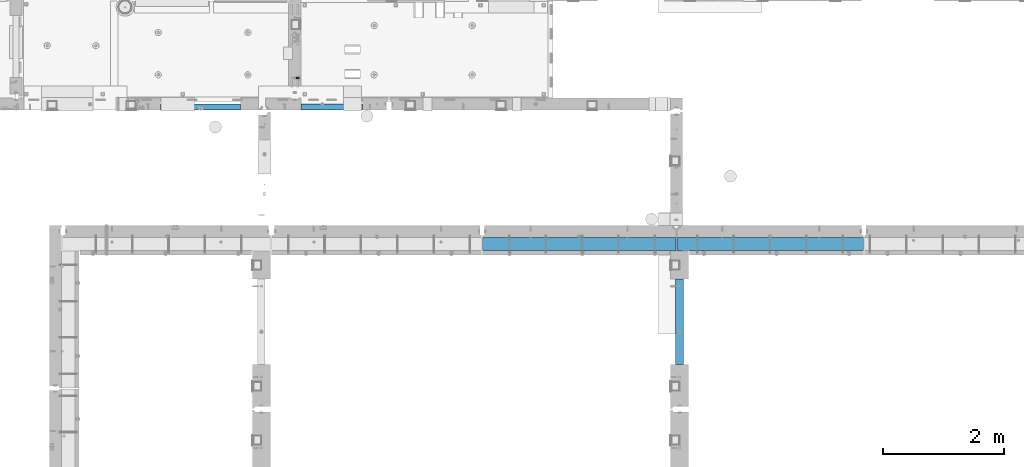
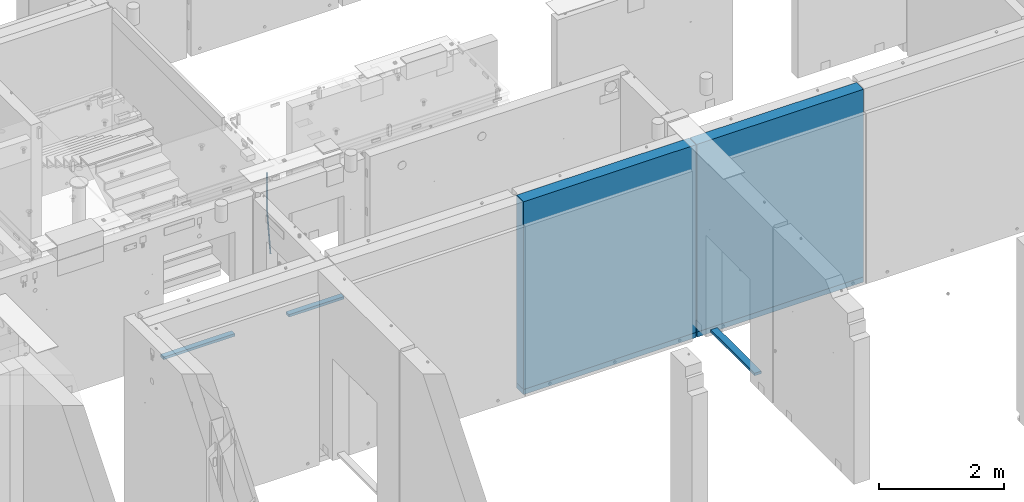
# One storey, part 80 of 264: 8 beams, 8 elements without a shape of their own.
"""IFC2X3 building model written with IfcOpenShell, lengths in millimetres."""

from ifc_helpers import new_model, si_unit, frame, origin_with_axes, place, context, subcontext, project, spatial, faceted_brep, material, type_object, element, aggregate, save


model = new_model("IFC2X3")

# Units and contexts
model_context = context("Model", 3, precision=1e-05, world=origin_with_axes())
body_context = subcontext(model_context, "Body", "Model", "MODEL_VIEW")
ifc_project = project(units=[si_unit("LENGTHUNIT", "METRE", prefix="MILLI"), si_unit("AREAUNIT", "SQUARE_METRE"), si_unit("VOLUMEUNIT", "CUBIC_METRE"), si_unit("MASSUNIT", "GRAM", prefix="KILO"), si_unit("TIMEUNIT", "SECOND"), si_unit("PLANEANGLEUNIT", "RADIAN"), si_unit("SOLIDANGLEUNIT", "STERADIAN"), si_unit("THERMODYNAMICTEMPERATUREUNIT", "DEGREE_CELSIUS"), si_unit("LUMINOUSINTENSITYUNIT", "LUMEN")], contexts=[model_context])

# Site, building, storey
site_placement = place(None, origin_with_axes())
site = spatial("IfcSite", under=ifc_project, at=site_placement, CompositionType="ELEMENT")
building_placement = place(site_placement, origin_with_axes())
building = spatial("IfcBuilding", under=site, at=building_placement, CompositionType="ELEMENT")
storey_placement = place(building_placement, origin_with_axes())
storey = spatial("IfcBuildingStorey", under=building, at=storey_placement, Name="K", CompositionType="ELEMENT", Elevation=0.0)

# Assembly, beam
assembly_1_placement = place(storey_placement, origin_with_axes())
assembly_1 = element("IfcElementAssembly", 1, at=assembly_1_placement, inside=storey, AssemblyPlace="NOTDEFINED", PredefinedType="REINFORCEMENT_UNIT")
ifc_material_1 = material()
beam_type_1 = type_object("IfcBeamType", Name="D20", PredefinedType="NOTDEFINED")
beam_1_placement = place(assembly_1_placement, frame((22375.0, 15610.0024460395, 79795.0), z_axis=(0.99735846233968, 0.0, 0.0726367510247368), x_axis=(-0.0726367510247384, 0.0, 0.99735846233968)))
beam_1 = element("IfcBeam", 2, at=beam_1_placement, type_object=beam_type_1, material=ifc_material_1, Name="JM20", ObjectType="D20", context=body_context, shape_type="Brep", body=[
    faceted_brep([(0.0, -10.0, 0.0), (-4.19531716033816e-08, -7.07106781186667, -7.07106781187031), (893.04549610398, -7.07106781186485, -7.0710675745504), (893.045496091479, -10.0, 2.30564182857051e-07), (0.0, 0.0, -10.0), (893.045496104736, 0.0, -9.99999976268737), (4.196772351861e-08, 7.07106781186303, -7.07106781186667), (893.04549610398, 7.07106781186485, -7.0710675745504), (0.0, 10.0, 0.0), (893.045496102088, 10.0, 2.37316271523014e-07), (4.196772351861e-08, 7.07106781185939, 7.07106781185939), (893.045496100211, 7.07106781186485, 7.0710680491793), (0.0, 0.0, 10.0), (893.045496099425, 0.0, 10.0000002373126), (-4.19531716033816e-08, -7.07106781187031, 7.07106781185939), (893.045496100211, -7.07106781186485, 7.0710680491793), (897.190953021025, -7.07106781186485, -6.92031220680656), (896.677333640066, -10.0, 0.132077120331815), (897.403701138901, 0.0, -9.84150751029665), (897.190953021025, 7.07106781186485, -6.92031220680656), (896.677333629617, 10.0, 0.132077113215928), (896.163714238195, 7.07106781186485, 7.18446643323841), (895.950966120377, 0.0, 10.1056617367321), (896.163714238195, -7.07106781186485, 7.18446643323841), (1601.00854794709, -7.07106781186485, 44.3381122681312), (1600.49492855495, -10.0, 51.3905015880737), (1601.22129606521, 0.0, 41.4169169646775), (1601.00854794709, 7.07106781186485, 44.3381122681312), (1600.49492855495, 10.0, 51.3905015880737), (1599.98130916282, 7.07106781186485, 58.4428909080125), (1599.76856104469, 0.0, 61.3640862114698), (1599.98130916282, -7.07106781186485, 58.4428909080125)], [[[0, 1, 2, 3]], [[1, 4, 5, 2]], [[4, 6, 7, 5]], [[6, 8, 9, 7]], [[8, 10, 11, 9]], [[10, 12, 13, 11]], [[12, 14, 15, 13]], [[14, 0, 3, 15]], [[14, 12, 10, 8, 6, 4, 1, 0]], [[3, 2, 16, 17]], [[2, 5, 18, 16]], [[5, 7, 19, 18]], [[7, 9, 20, 19]], [[9, 11, 21, 20]], [[11, 13, 22, 21]], [[13, 15, 23, 22]], [[15, 3, 17, 23]], [[17, 16, 24, 25]], [[16, 18, 26, 24]], [[18, 19, 27, 26]], [[19, 20, 28, 27]], [[20, 21, 29, 28]], [[21, 22, 30, 29]], [[22, 23, 31, 30]], [[23, 17, 25, 31]], [[26, 27, 28, 29, 30, 31, 25, 24]]]),
])
aggregate(assembly_1, [beam_1])

assembly_2_placement = place(storey_placement, origin_with_axes())
assembly_2 = element("IfcElementAssembly", 3, at=assembly_2_placement, inside=storey, AssemblyPlace="NOTDEFINED", PredefinedType="REINFORCEMENT_UNIT")
ifc_material_2 = material(Name="TIMBER/PUU")
beam_type_2 = type_object("IfcBeamType", PredefinedType="NOTDEFINED")
beam_2_placement = place(assembly_2_placement, frame((28660.0, 12290.0, 78115.0), z_axis=(0.0, 0.0, 1.0), x_axis=(0.0, -1.0, 0.0)))
beam_2 = element("IfcBeam", 4, at=beam_2_placement, type_object=beam_type_2, material=ifc_material_2, context=body_context, shape_type="Brep", body=[
    faceted_brep([(0.0, 62.5, -25.0), (0.0, 62.5, 25.0), (1410.00023037194, 62.5, 25.0), (1410.00023037194, 62.5, -25.0), (0.0, -62.5, 25.0), (1410.00023037194, -62.5, 25.0), (0.0, -62.5, -25.0), (1410.00023037194, -62.5, -25.0)], [[[0, 1, 2, 3]], [[1, 4, 5, 2]], [[4, 6, 7, 5]], [[6, 0, 3, 7]], [[5, 7, 3, 2]], [[6, 4, 1, 0]]]),
])
aggregate(assembly_2, [beam_2])

assembly_3_placement = place(storey_placement, origin_with_axes())
assembly_3 = element("IfcElementAssembly", 5, at=assembly_3_placement, inside=storey, AssemblyPlace="NOTDEFINED", PredefinedType="REINFORCEMENT_UNIT")
ifc_material_3 = material(Name="TIMBER/T24")
beam_type_3 = type_object("IfcBeamType", PredefinedType="NOTDEFINED")
beam_3_placement = place(assembly_3_placement, frame((22409.9994690485, 15130.0, 78880.0), z_axis=(0.0, 0.0, 1.0), x_axis=(1.0, 0.0, 0.0)))
beam_3 = element("IfcBeam", 6, at=beam_3_placement, type_object=beam_type_3, material=ifc_material_3, context=body_context, shape_type="Brep", body=[
    faceted_brep([(0.0, 50.0, -25.0), (0.0, 50.0, 25.0), (1019.99696415685, 50.0, 25.0), (1019.99696415685, 50.0, -25.0), (0.0, -50.0, 25.0), (1019.99696415685, -50.0, 25.0), (0.0, -50.0, -25.0), (1019.99696415685, -50.0, -25.0)], [[[0, 1, 2, 3]], [[1, 4, 5, 2]], [[4, 6, 7, 5]], [[6, 0, 3, 7]], [[5, 7, 3, 2]], [[6, 4, 1, 0]]]),
])
aggregate(assembly_3, [beam_3])

assembly_4_placement = place(storey_placement, origin_with_axes())
assembly_4 = element("IfcElementAssembly", 7, at=assembly_4_placement, inside=storey, AssemblyPlace="NOTDEFINED", PredefinedType="REINFORCEMENT_UNIT")
beam_4_placement = place(assembly_4_placement, frame((20094.9972693255, 15130.0, 78860.0), z_axis=(0.0, 0.0, 1.0), x_axis=(1.0, 0.0, 0.0)))
beam_4 = element("IfcBeam", 8, at=beam_4_placement, type_object=beam_type_3, material=ifc_material_3, context=body_context, shape_type="Brep", body=[
    faceted_brep([(0.0, 50.0, -25.0), (0.0, 50.0, 25.0), (1320.00518798828, 50.0, 25.0), (1320.00518798828, 50.0, -25.0), (0.0, -50.0, 25.0), (1320.00518798828, -50.0, 25.0), (0.0, -50.0, -25.0), (1320.00518798828, -50.0, -25.0)], [[[0, 1, 2, 3]], [[1, 4, 5, 2]], [[4, 6, 7, 5]], [[6, 0, 3, 7]], [[5, 7, 3, 2]], [[6, 4, 1, 0]]]),
])
aggregate(assembly_4, [beam_4])

assembly_5_placement = place(storey_placement, origin_with_axes())
assembly_5 = element("IfcElementAssembly", 9, at=assembly_5_placement, inside=storey, AssemblyPlace="NOTDEFINED", PredefinedType="REINFORCEMENT_UNIT")
ifc_material_4 = material(Name="CONCRETE/C25/30")
beam_type_4 = type_object("IfcBeamType", PredefinedType="NOTDEFINED")
beam_5_placement = place(assembly_5_placement, frame((28600.0, 12870.0018965848, 77750.0), z_axis=(0.0, 0.0, 1.0), x_axis=(-1.0, 3.00000001838171e-08, 0.0)))
beam_5 = element("IfcBeam", 10, at=beam_5_placement, type_object=beam_type_4, material=ifc_material_4, context=body_context, shape_type="Brep", body=[
    faceted_brep([(-3.63797880709171e-12, 109.999999999996, -50.0), (-3.63797880709171e-12, 109.999999999996, 50.0), (3190.0, 110.0, 50.0), (3190.0, 110.0, -50.0), (-3.63797880709171e-12, -110.0, 50.0), (3190.0, -110.0, 50.0), (-3.63797880709171e-12, -110.0, -50.0), (3190.0, -110.0, -50.0)], [[[0, 1, 2, 3]], [[1, 4, 5, 2]], [[4, 6, 7, 5]], [[6, 0, 3, 7]], [[5, 7, 3, 2]], [[6, 4, 1, 0]]]),
])

assembly_6_placement = place(storey_placement, origin_with_axes())
assembly_6 = element("IfcElementAssembly", 11, at=assembly_6_placement, inside=storey, AssemblyPlace="NOTDEFINED", PredefinedType="REINFORCEMENT_UNIT")
beam_6_placement = place(assembly_6_placement, frame((31695.0024573137, 12870.0018965848, 77750.0), z_axis=(0.0, 0.0, 1.0), x_axis=(-1.0, 3.00000001838171e-08, 0.0)))
beam_6 = element("IfcBeam", 12, at=beam_6_placement, type_object=beam_type_4, material=ifc_material_4, context=body_context, shape_type="Brep", body=[
    faceted_brep([(-3.63797880709171e-12, 109.999999999996, -50.0), (-3.63797880709171e-12, 109.999999999996, 50.0), (3080.00245731375, 110.0, 50.0), (3080.00245731375, 110.0, -50.0), (-3.63797880709171e-12, -110.0, 50.0), (3080.00245731375, -110.0, 50.0), (-3.63797880709171e-12, -110.0, -50.0), (3080.00245731375, -110.0, -50.0)], [[[0, 1, 2, 3]], [[1, 4, 5, 2]], [[4, 6, 7, 5]], [[6, 0, 3, 7]], [[5, 7, 3, 2]], [[6, 4, 1, 0]]]),
])

# Assembly
assembly_7_placement = place(assembly_5_placement, origin_with_axes())
assembly_7 = element("IfcElementAssembly", 13, at=assembly_7_placement, Name="Steel Assembly", AssemblyPlace="NOTDEFINED", PredefinedType="NOTDEFINED")

aggregate(assembly_5, [assembly_7, beam_5])

# Beam
ifc_material_5 = material(Name="EPS100")
beam_type_5 = type_object("IfcBeamType", PredefinedType="NOTDEFINED")
beam_7_placement = place(assembly_7_placement, frame((28600.0, 12870.0018965848, 79635.0), z_axis=(0.0, 0.0, 1.0), x_axis=(-1.0, 3.00000001838171e-08, 0.0)))
beam_7 = element("IfcBeam", 14, at=beam_7_placement, type_object=beam_type_5, material=ifc_material_5, context=body_context, shape_type="Brep", body=[
    faceted_brep([(0.0, 110.0, -1835.0), (0.0, 110.0, 1835.0), (3190.0, 110.0, 1835.0), (3190.0, 110.0, -1835.0), (0.0, -110.0, 1835.0), (3190.0, -110.0, 1835.0), (0.0, -110.0, -1835.0), (3190.0, -110.0, -1835.0)], [[[0, 1, 2, 3]], [[1, 4, 5, 2]], [[4, 6, 7, 5]], [[6, 0, 3, 7]], [[5, 7, 3, 2]], [[6, 4, 1, 0]]]),
])

aggregate(assembly_7, [beam_7])

# Assembly
assembly_8_placement = place(assembly_6_placement, origin_with_axes())
assembly_8 = element("IfcElementAssembly", 15, at=assembly_8_placement, Name="Steel Assembly", AssemblyPlace="NOTDEFINED", PredefinedType="NOTDEFINED")

aggregate(assembly_6, [assembly_8, beam_6])

# Beam
beam_8_placement = place(assembly_8_placement, frame((31695.0024573137, 12870.0018965848, 79635.0), z_axis=(0.0, 0.0, 1.0), x_axis=(-1.0, 3.00000001838171e-08, 0.0)))
beam_8 = element("IfcBeam", 16, at=beam_8_placement, type_object=beam_type_5, material=ifc_material_5, context=body_context, shape_type="Brep", body=[
    faceted_brep([(0.0, 110.0, -1835.0), (0.0, 110.0, 1835.0), (3080.00245731375, 110.0, 1835.0), (3080.00245731375, 110.0, -1835.0), (0.0, -110.0, 1835.0), (3080.00245731375, -110.0, 1835.0), (0.0, -110.0, -1835.0), (3080.00245731375, -110.0, -1835.0)], [[[0, 1, 2, 3]], [[1, 4, 5, 2]], [[4, 6, 7, 5]], [[6, 0, 3, 7]], [[5, 7, 3, 2]], [[6, 4, 1, 0]]]),
])

aggregate(assembly_8, [beam_8])

save(model, "model.ifc")
